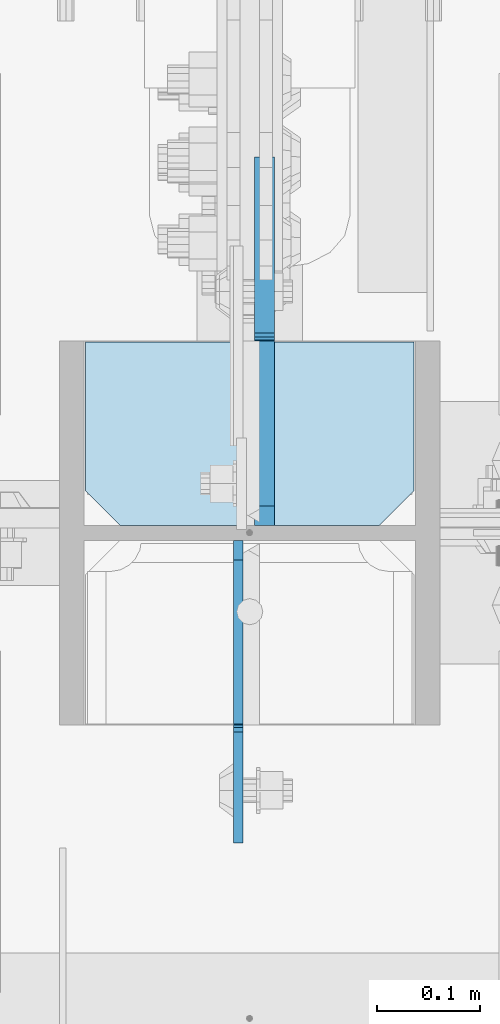
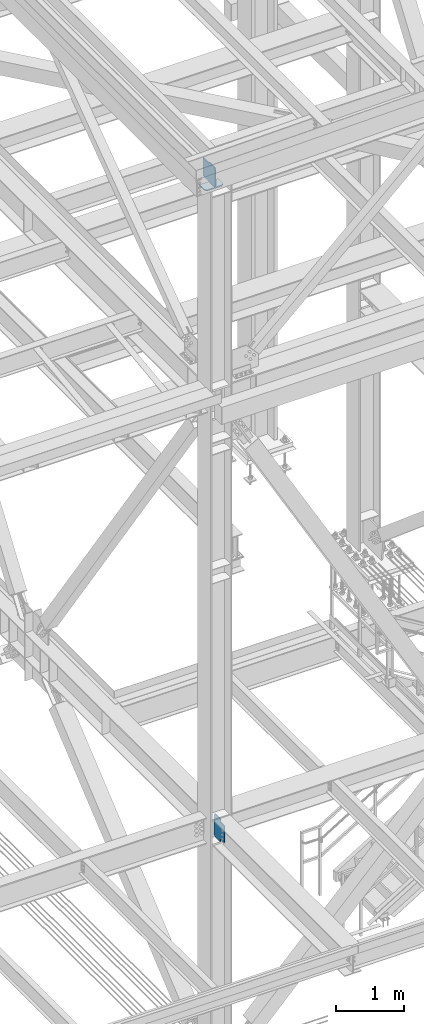
# One storey, part 3098 of 3843: 3 plates, 1 element without a shape of its own.
"""IFC2X3 building model written with IfcOpenShell, lengths in millimetres."""

from ifc_helpers import new_model, si_unit, frame, origin_with_axes, place, context, subcontext, project, spatial, faceted_brep, material, type_object, element, aggregate, save


model = new_model("IFC2X3")

# Units and contexts
model_context = context("Model", 3, precision=1e-05, world=origin_with_axes())
body_context = subcontext(model_context, "Body", "Model", "MODEL_VIEW")
ifc_project = project(units=[si_unit("LENGTHUNIT", "METRE", prefix="MILLI"), si_unit("AREAUNIT", "SQUARE_METRE"), si_unit("VOLUMEUNIT", "CUBIC_METRE"), si_unit("MASSUNIT", "GRAM", prefix="KILO"), si_unit("TIMEUNIT", "SECOND"), si_unit("PLANEANGLEUNIT", "RADIAN"), si_unit("SOLIDANGLEUNIT", "STERADIAN"), si_unit("THERMODYNAMICTEMPERATUREUNIT", "DEGREE_CELSIUS"), si_unit("LUMINOUSINTENSITYUNIT", "LUMEN")], contexts=[model_context])

# Site, building, storey
site_placement = place(None, origin_with_axes())
site = spatial("IfcSite", under=ifc_project, at=site_placement, CompositionType="ELEMENT")
building_placement = place(site_placement, origin_with_axes())
building = spatial("IfcBuilding", under=site, at=building_placement, Name="Undefined", CompositionType="ELEMENT")
storey_placement = place(building_placement, origin_with_axes())
storey = spatial("IfcBuildingStorey", under=building, at=storey_placement, Name="Undefined", CompositionType="ELEMENT", Elevation=0.0)

# Assembly, plates
assembly_placement = place(storey_placement, origin_with_axes())
assembly = element("IfcElementAssembly", 1, at=assembly_placement, inside=storey, Name="COLUMN", AssemblyPlace="NOTDEFINED", PredefinedType="RIGID_FRAME")
ifc_material = material(Name="STEEL/A572-50")
plate_type_1 = type_object("IfcPlateType", PredefinedType="NOTDEFINED")
plate_1_placement = place(assembly_placement, frame((77171.55, 15183.64375, 45902.414563992), z_axis=(-1.0, 0.0, 0.0), x_axis=(0.0, -1.0, 0.0)))
plate_1 = element("IfcPlate", 2, at=plate_1_placement, type_object=plate_type_1, material=ifc_material, Name="PLATE", context=body_context, shape_type="Brep", body=[
    faceted_brep([(0.0, -9.52500000000146, 0.0), (0.0, -9.52500000000146, 317.5), (0.0, 9.52500000000146, 317.5), (0.0, 9.52500000000146, 0.0), (144.462501525879, -9.52500000000146, 317.5), (144.462501525879, 9.52500000000146, 317.5), (177.800003051758, -9.52500000000146, 284.162498474121), (177.800003051758, 9.52500000000146, 284.162498474121), (177.800003051758, -9.52500000000146, 33.3375015258789), (177.800003051758, 9.52500000000146, 33.3375015258789), (144.462501525879, -9.52500000000146, 0.0), (144.462501525879, 9.52500000000146, 0.0)], [[[0, 1, 2, 3]], [[1, 4, 5, 2]], [[4, 6, 7, 5]], [[6, 8, 9, 7]], [[8, 10, 11, 9]], [[10, 0, 3, 11]], [[5, 7, 9, 11, 3, 2]], [[10, 8, 6, 4, 1, 0]]]),
])
plate_type_2 = type_object("IfcPlateType", PredefinedType="NOTDEFINED")
plate_2_placement = place(assembly_placement, frame((77001.6875, 14991.55625, 34391.6), z_axis=(0.0, -0.707106781186682, 0.707106781186413), x_axis=(0.0, -0.707106781186548, -0.707106781186548)))
plate_2 = element("IfcPlate", 3, at=plate_2_placement, type_object=plate_type_2, material=ifc_material, Name="PLATE", context=body_context, shape_type="Brep", body=[
    faceted_brep([(0.0, -4.76249999999709, 0.0), (-262.672491540012, -4.76249999999709, 262.672491540012), (-262.672491540012, 4.76249999999709, 262.672491540012), (0.0, 4.76249999999709, 0.0), (-262.672491539946, -4.76249999999709, 289.613259903157), (-262.672491539946, 4.76249999999709, 289.613259903157), (-150.581363970181, -4.76249999999709, 401.704387472921), (-150.581363970181, 4.76249999999709, 401.704387472921), (-122.518063457137, -4.76249999999709, 373.641086959873), (-122.518063457137, 4.76249999999709, 373.641086959873), (-118.397886988991, -4.76249999999709, 370.888073059405), (-118.397886988991, 4.76249999999709, 370.888073059405), (-113.537807470952, -4.76249999999709, 369.921343136823), (-113.537807470952, 4.76249999999709, 369.921343136823), (-108.677727952912, -4.76249999999709, 370.888073059412), (-108.677727952912, 4.76249999999709, 370.888073059412), (-104.557551484759, -4.76249999999709, 373.641086959895), (-104.557551484759, 4.76249999999709, 373.641086959895), (-32.154236373739, -4.76249999999709, 446.044402070913), (-32.154236373739, 4.76249999999709, 446.044402070913), (183.371910530885, -4.76249999999709, 230.518255166287), (183.371910530885, 4.76249999999709, 230.518255166287), (110.968595419872, -4.76249999999709, 158.114940055269), (110.968595419872, 4.76249999999709, 158.114940055269), (108.215581519391, -4.76249999999709, 153.994763587116), (108.215581519391, 4.76249999999709, 153.994763587116), (107.2488515968, -4.76249999999709, 149.134684069073), (107.2488515968, 4.76249999999709, 149.134684069073), (108.215581519376, -4.76249999999709, 144.274604551038), (108.215581519376, 4.76249999999709, 144.274604551038), (110.96859541985, -4.76249999999709, 140.154428082891), (110.96859541985, 4.76249999999709, 140.154428082891), (139.031895932902, -4.76249999999709, 112.091127569838), (139.031895932902, 4.76249999999709, 112.091127569838), (26.9407683631998, -4.76249999999709, 1.30967237055302e-10), (26.9407683631998, 4.76249999999709, 1.30967237055302e-10)], [[[0, 1, 2, 3]], [[1, 4, 5, 2]], [[4, 6, 7, 5]], [[6, 8, 9, 7]], [[8, 10, 11, 9]], [[10, 12, 13, 11]], [[12, 14, 15, 13]], [[14, 16, 17, 15]], [[16, 18, 19, 17]], [[18, 20, 21, 19]], [[20, 22, 23, 21]], [[22, 24, 25, 23]], [[24, 26, 27, 25]], [[26, 28, 29, 27]], [[28, 30, 31, 29]], [[30, 32, 33, 31]], [[32, 34, 35, 33]], [[34, 0, 3, 35]], [[5, 7, 9, 11, 13, 15, 17, 19, 21, 23, 25, 27, 29, 31, 33, 35, 3, 2]], [[34, 32, 30, 28, 26, 24, 22, 20, 18, 16, 14, 12, 10, 8, 6, 4, 1, 0]]]),
])
plate_type_3 = type_object("IfcPlateType", PredefinedType="NOTDEFINED")
plate_3_placement = place(assembly_placement, frame((77027.0875006341, 15005.84375, 45930.9895639882), z_axis=(0.0, 0.707106781186548, 0.707106781186548), x_axis=(5.70000238222118e-08, 0.707106781186546, -0.707106781186546)))
plate_3 = element("IfcPlate", 4, at=plate_3_placement, type_object=plate_type_3, material=ifc_material, Name="PLATE", context=body_context, shape_type="Brep", body=[
    faceted_brep([(0.0, -9.52500000000146, 0.0), (-214.403614889528, -9.52499999999418, 214.403614889488), (-214.403614889528, 9.52499999999418, 214.403614889488), (0.0, 9.52500000000146, 0.0), (-214.403614889336, -9.52499999999418, 241.344383252748), (-214.403614889336, 9.52499999999418, 241.344383252748), (-101.589147367522, -9.52499999999418, 354.158850774584), (-101.589147367522, 9.52499999999418, 354.158850774584), (-93.731422658424, -9.52499999999418, 346.301126065489), (-93.731422658424, 9.52499999999418, 346.301126065489), (-89.6112461902703, -9.52499999999418, 343.548112165008), (-89.6112461902703, 9.52499999999418, 343.548112165008), (-84.7511666722385, -9.52499999999418, 342.581382242439), (-84.7511666722385, 9.52499999999418, 342.581382242439), (-79.8910871541921, -9.52499999999418, 343.548112165023), (-79.8910871541921, 9.52499999999418, 343.548112165023), (-75.770910686042, -9.52499999999418, 346.301126065511), (-75.770910686042, 9.52499999999418, 346.301126065511), (40.9724185538689, -9.52500000000146, 463.044456243078), (40.9724185538689, 9.52500000000146, 463.044456243078), (265.478821579974, -9.52500000000146, 238.538053217882), (265.478821579974, 9.52500000000146, 238.538053217882), (26.9407683632344, -9.52499999999964, 2.03726813197136e-10), (26.9407683632344, 9.52499999999964, 2.03726813197136e-10)], [[[0, 1, 2, 3]], [[1, 4, 5, 2]], [[4, 6, 7, 5]], [[6, 8, 9, 7]], [[8, 10, 11, 9]], [[10, 12, 13, 11]], [[12, 14, 15, 13]], [[14, 16, 17, 15]], [[16, 18, 19, 17]], [[18, 20, 21, 19]], [[20, 22, 23, 21]], [[22, 0, 3, 23]], [[5, 7, 9, 11, 13, 15, 17, 19, 21, 23, 3, 2]], [[22, 20, 18, 16, 14, 12, 10, 8, 6, 4, 1, 0]]]),
])
aggregate(assembly, [plate_2, plate_1, plate_3])

save(model, "model.ifc")
